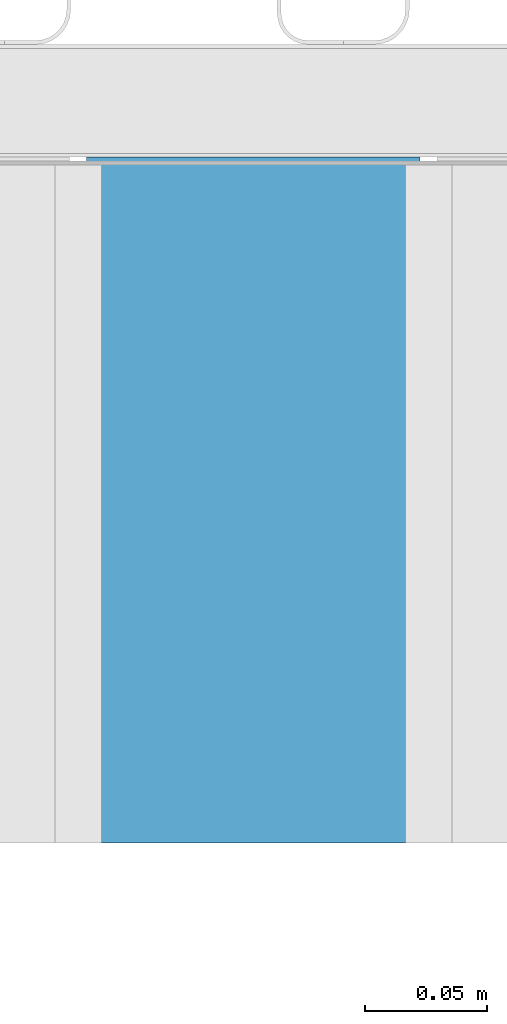
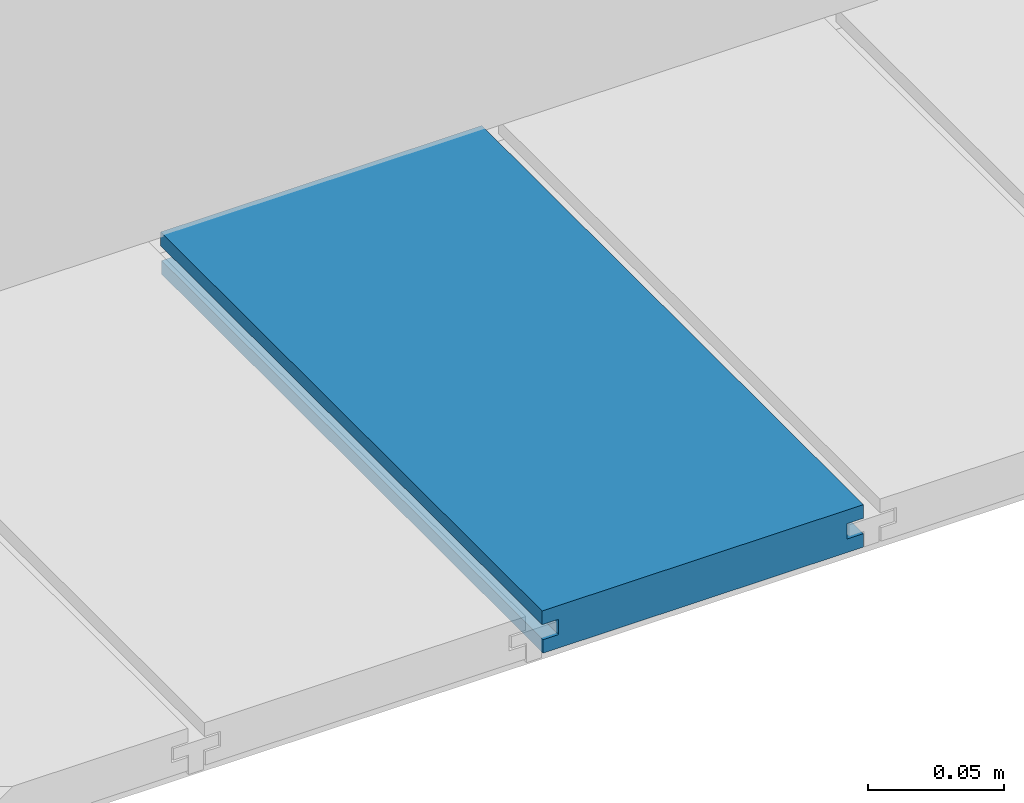
# One storey, part 15 of 33: 1 wall.
"""IFC4 building model written with IfcOpenShell, lengths in feet."""

from ifc_helpers import new_model, entity, si_unit, converted_unit, derived_unit, direction, frame, origin, place, context, subcontext, project, spatial, material, type_object, element, save


model = new_model("IFC4")

# Units and contexts
model_context = context("Model", 3, precision=0.0001, world=origin(), true_north=direction((6.12303176911189e-17, 1.0)))
body_context = subcontext(model_context, "Body", "Model", "MODEL_VIEW")
ifc_project = project(units=[converted_unit("LENGTHUNIT", "FOOT", entity("IfcRatioMeasure", 0.3048), si_unit("LENGTHUNIT", "METRE"), dimensions=[1, 0, 0, 0, 0, 0, 0]), converted_unit("AREAUNIT", "SQUARE FOOT", entity("IfcRatioMeasure", 0.09290304), si_unit("AREAUNIT", "SQUARE_METRE"), dimensions=[2, 0, 0, 0, 0, 0, 0]), converted_unit("VOLUMEUNIT", "CUBIC FOOT", entity("IfcRatioMeasure", 0.028316846592), si_unit("VOLUMEUNIT", "CUBIC_METRE"), dimensions=[3, 0, 0, 0, 0, 0, 0]), converted_unit("PLANEANGLEUNIT", "DEGREE", entity("IfcRatioMeasure", 0.0174532925199433), si_unit("PLANEANGLEUNIT", "RADIAN"), dimensions=[0, 0, 0, 0, 0, 0, 0]), si_unit("MASSUNIT", "GRAM", prefix="KILO"), derived_unit("MASSDENSITYUNIT", [(si_unit("MASSUNIT", "GRAM", prefix="KILO"), 1), (si_unit("LENGTHUNIT", "METRE"), -3)]), derived_unit("MOMENTOFINERTIAUNIT", [(si_unit("LENGTHUNIT", "METRE"), 4)]), si_unit("TIMEUNIT", "SECOND"), si_unit("FREQUENCYUNIT", "HERTZ"), si_unit("THERMODYNAMICTEMPERATUREUNIT", "DEGREE_CELSIUS"), derived_unit("THERMALTRANSMITTANCEUNIT", [(si_unit("MASSUNIT", "GRAM", prefix="KILO"), 1), (si_unit("THERMODYNAMICTEMPERATUREUNIT", "KELVIN"), -1), (si_unit("TIMEUNIT", "SECOND"), -3)]), derived_unit("VOLUMETRICFLOWRATEUNIT", [(si_unit("LENGTHUNIT", "METRE"), 3), (si_unit("TIMEUNIT", "SECOND"), -1)]), si_unit("ELECTRICCURRENTUNIT", "AMPERE"), si_unit("ELECTRICVOLTAGEUNIT", "VOLT"), si_unit("POWERUNIT", "WATT"), si_unit("FORCEUNIT", "NEWTON"), si_unit("ILLUMINANCEUNIT", "LUX"), si_unit("LUMINOUSFLUXUNIT", "LUMEN"), si_unit("LUMINOUSINTENSITYUNIT", "CANDELA"), derived_unit("USERDEFINED", [(si_unit("MASSUNIT", "GRAM", prefix="KILO"), -1), (si_unit("LENGTHUNIT", "METRE"), -2), (si_unit("TIMEUNIT", "SECOND"), 3), (si_unit("LUMINOUSFLUXUNIT", "LUMEN"), 1)]), derived_unit("LINEARVELOCITYUNIT", [(si_unit("LENGTHUNIT", "METRE"), 1), (si_unit("TIMEUNIT", "SECOND"), -1)]), si_unit("PRESSUREUNIT", "PASCAL"), derived_unit("USERDEFINED", [(si_unit("LENGTHUNIT", "METRE"), -2), (si_unit("MASSUNIT", "GRAM", prefix="KILO"), 1), (si_unit("TIMEUNIT", "SECOND"), -2)]), derived_unit("LINEARFORCEUNIT", [(si_unit("MASSUNIT", "GRAM", prefix="KILO"), 1), (si_unit("LENGTHUNIT", "METRE"), 1), (si_unit("TIMEUNIT", "SECOND"), -2), (si_unit("LENGTHUNIT", "METRE"), -1)]), derived_unit("PLANARFORCEUNIT", [(si_unit("MASSUNIT", "GRAM", prefix="KILO"), 1), (si_unit("LENGTHUNIT", "METRE"), 1), (si_unit("TIMEUNIT", "SECOND"), -2), (si_unit("LENGTHUNIT", "METRE"), -2)])], contexts=[model_context])

# Site, building, storey
site_placement = place(None, origin())
site = spatial("IfcSite", under=ifc_project, at=site_placement, CompositionType="ELEMENT")
building_placement = place(site_placement, origin())
building = spatial("IfcBuilding", under=site, at=building_placement, CompositionType="ELEMENT")
storey_placement = place(building_placement, frame((0.0, 0.0, 10.0)))
storey = spatial("IfcBuildingStorey", under=building, at=storey_placement, Name="2ND FLOOR", CompositionType="ELEMENT", Elevation=10.0000000000002)

# Wall
ifc_material = material(Name="COMPOSITE DECKING W/ HIDDEN FASTENERS", Category="Materials")
wall_type = type_object("IfcWallType", Name="Generic Models 734:Generic Models 1", PredefinedType="NOTDEFINED", material=ifc_material)
wall_placement = place(storey_placement, frame((1488.24305872981, 3.04611392999271, 0.682902157150147), z_axis=(0.0, 0.0, 1.0), x_axis=(0.0, 1.0, 0.0)))
cartesian_point_1 = entity("IfcCartesianPoint", [0.919003339851617, -0.446740923891412, 0.0])
vertex_point_1 = entity("IfcVertexPoint", cartesian_point_1)
cartesian_point_2 = entity("IfcCartesianPoint", [0.919003339851619, -0.00132475379450625, 0.0])
vertex_point_2 = entity("IfcVertexPoint", cartesian_point_2)
ifc_direction_1 = entity("IfcDirection", [0.0, 1.0, 0.0])
edge_curve_1 = entity("IfcEdgeCurve", vertex_point_1, vertex_point_2, entity("IfcTrimmedCurve", entity("IfcLine", cartesian_point_1, entity("IfcVector", ifc_direction_1, 1.0)), [cartesian_point_1], [cartesian_point_2], True, "CARTESIAN"), True)
cartesian_point_3 = entity("IfcCartesianPoint", [0.919003339851619, -0.00132475379450625, 0.0198779960861479])
vertex_point_3 = entity("IfcVertexPoint", cartesian_point_3)
ifc_direction_2 = entity("IfcDirection", [0.0, 0.0, 1.0])
edge_curve_2 = entity("IfcEdgeCurve", vertex_point_2, vertex_point_3, entity("IfcTrimmedCurve", entity("IfcLine", cartesian_point_2, entity("IfcVector", ifc_direction_2, 1.0)), [cartesian_point_2], [cartesian_point_3], True, "CARTESIAN"), True)
cartesian_point_4 = entity("IfcCartesianPoint", [0.919003339851619, -0.0228400010807945, 0.0198779960861479])
vertex_point_4 = entity("IfcVertexPoint", cartesian_point_4)
ifc_direction_3 = entity("IfcDirection", [0.0, -1.0, 0.0])
edge_curve_3 = entity("IfcEdgeCurve", vertex_point_3, vertex_point_4, entity("IfcTrimmedCurve", entity("IfcLine", cartesian_point_3, entity("IfcVector", ifc_direction_3, 1.0)), [cartesian_point_3], [cartesian_point_4], True, "CARTESIAN"), True)
cartesian_point_5 = entity("IfcCartesianPoint", [0.919003339851619, -0.0228400010807945, 0.0422987663426522])
vertex_point_5 = entity("IfcVertexPoint", cartesian_point_5)
edge_curve_4 = entity("IfcEdgeCurve", vertex_point_4, vertex_point_5, entity("IfcTrimmedCurve", entity("IfcLine", cartesian_point_4, entity("IfcVector", ifc_direction_2, 1.0)), [cartesian_point_4], [cartesian_point_5], True, "CARTESIAN"), True)
cartesian_point_6 = entity("IfcCartesianPoint", [0.919003339851619, 0.0, 0.0422987663426522])
vertex_point_6 = entity("IfcVertexPoint", cartesian_point_6)
edge_curve_5 = entity("IfcEdgeCurve", vertex_point_5, vertex_point_6, entity("IfcTrimmedCurve", entity("IfcLine", cartesian_point_5, entity("IfcVector", ifc_direction_1, 1.0)), [cartesian_point_5], [cartesian_point_6], True, "CARTESIAN"), True)
cartesian_point_7 = entity("IfcCartesianPoint", [0.919003339851619, 0.0, 0.0625000000000551])
vertex_point_7 = entity("IfcVertexPoint", cartesian_point_7)
edge_curve_6 = entity("IfcEdgeCurve", vertex_point_6, vertex_point_7, entity("IfcTrimmedCurve", entity("IfcLine", cartesian_point_6, entity("IfcVector", ifc_direction_2, 1.0)), [cartesian_point_6], [cartesian_point_7], True, "CARTESIAN"), True)
cartesian_point_8 = entity("IfcCartesianPoint", [0.919003339851617, -0.446740923891639, 0.0625])
vertex_point_8 = entity("IfcVertexPoint", cartesian_point_8)
edge_curve_7 = entity("IfcEdgeCurve", vertex_point_7, vertex_point_8, entity("IfcTrimmedCurve", entity("IfcLine", cartesian_point_7, entity("IfcVector", ifc_direction_3, 1.0)), [cartesian_point_7], [cartesian_point_8], True, "CARTESIAN"), True)
cartesian_point_9 = entity("IfcCartesianPoint", [0.919003339851617, -0.446740923891639, 0.0422987663426522])
vertex_point_9 = entity("IfcVertexPoint", cartesian_point_9)
ifc_direction_4 = entity("IfcDirection", [0.0, 0.0, -1.0])
edge_curve_8 = entity("IfcEdgeCurve", vertex_point_8, vertex_point_9, entity("IfcTrimmedCurve", entity("IfcLine", cartesian_point_8, entity("IfcVector", ifc_direction_4, 1.0)), [cartesian_point_8], [cartesian_point_9], True, "CARTESIAN"), True)
cartesian_point_10 = entity("IfcCartesianPoint", [0.919003339851617, -0.423900922810617, 0.0422987663426522])
vertex_point_10 = entity("IfcVertexPoint", cartesian_point_10)
edge_curve_9 = entity("IfcEdgeCurve", vertex_point_9, vertex_point_10, entity("IfcTrimmedCurve", entity("IfcLine", cartesian_point_9, entity("IfcVector", ifc_direction_1, 1.0)), [cartesian_point_9], [cartesian_point_10], True, "CARTESIAN"), True)
cartesian_point_11 = entity("IfcCartesianPoint", [0.919003339851617, -0.423900922810617, 0.0198779960861479])
vertex_point_11 = entity("IfcVertexPoint", cartesian_point_11)
edge_curve_10 = entity("IfcEdgeCurve", vertex_point_10, vertex_point_11, entity("IfcTrimmedCurve", entity("IfcLine", cartesian_point_10, entity("IfcVector", ifc_direction_4, 1.0)), [cartesian_point_10], [cartesian_point_11], True, "CARTESIAN"), True)
cartesian_point_12 = entity("IfcCartesianPoint", [0.919003339851617, -0.446740923891412, 0.0198779960861479])
vertex_point_12 = entity("IfcVertexPoint", cartesian_point_12)
edge_curve_11 = entity("IfcEdgeCurve", vertex_point_11, vertex_point_12, entity("IfcTrimmedCurve", entity("IfcLine", cartesian_point_11, entity("IfcVector", ifc_direction_3, 1.0)), [cartesian_point_11], [cartesian_point_12], True, "CARTESIAN"), True)
edge_curve_12 = entity("IfcEdgeCurve", vertex_point_12, vertex_point_1, entity("IfcTrimmedCurve", entity("IfcLine", cartesian_point_12, entity("IfcVector", ifc_direction_4, 1.0)), [cartesian_point_12], [cartesian_point_1], True, "CARTESIAN"), True)
ifc_direction_5 = entity("IfcDirection", [1.0, 0.0, 0.0])
cartesian_point_13 = entity("IfcCartesianPoint", [0.0, -0.446740923891412, 0.0])
vertex_point_13 = entity("IfcVertexPoint", cartesian_point_13)
cartesian_point_14 = entity("IfcCartesianPoint", [0.0, -0.446740923891412, 0.0198779960861479])
vertex_point_14 = entity("IfcVertexPoint", cartesian_point_14)
edge_curve_13 = entity("IfcEdgeCurve", vertex_point_13, vertex_point_14, entity("IfcTrimmedCurve", entity("IfcLine", cartesian_point_13, entity("IfcVector", ifc_direction_2, 1.0)), [cartesian_point_13], [cartesian_point_14], True, "CARTESIAN"), True)
cartesian_point_15 = entity("IfcCartesianPoint", [0.0, -0.423900922810617, 0.0198779960861479])
vertex_point_15 = entity("IfcVertexPoint", cartesian_point_15)
edge_curve_14 = entity("IfcEdgeCurve", vertex_point_14, vertex_point_15, entity("IfcTrimmedCurve", entity("IfcLine", cartesian_point_14, entity("IfcVector", ifc_direction_1, 1.0)), [cartesian_point_14], [cartesian_point_15], True, "CARTESIAN"), True)
cartesian_point_16 = entity("IfcCartesianPoint", [0.0, -0.423900922810617, 0.0422987663426522])
vertex_point_16 = entity("IfcVertexPoint", cartesian_point_16)
edge_curve_15 = entity("IfcEdgeCurve", vertex_point_15, vertex_point_16, entity("IfcTrimmedCurve", entity("IfcLine", cartesian_point_15, entity("IfcVector", ifc_direction_2, 1.0)), [cartesian_point_15], [cartesian_point_16], True, "CARTESIAN"), True)
cartesian_point_17 = entity("IfcCartesianPoint", [0.0, -0.446740923891639, 0.0422987663426522])
vertex_point_17 = entity("IfcVertexPoint", cartesian_point_17)
edge_curve_16 = entity("IfcEdgeCurve", vertex_point_16, vertex_point_17, entity("IfcTrimmedCurve", entity("IfcLine", cartesian_point_16, entity("IfcVector", ifc_direction_3, 1.0)), [cartesian_point_16], [cartesian_point_17], True, "CARTESIAN"), True)
cartesian_point_18 = entity("IfcCartesianPoint", [0.0, -0.446740923891639, 0.0625])
vertex_point_18 = entity("IfcVertexPoint", cartesian_point_18)
edge_curve_17 = entity("IfcEdgeCurve", vertex_point_17, vertex_point_18, entity("IfcTrimmedCurve", entity("IfcLine", cartesian_point_17, entity("IfcVector", ifc_direction_2, 1.0)), [cartesian_point_17], [cartesian_point_18], True, "CARTESIAN"), True)
cartesian_point_19 = entity("IfcCartesianPoint", [0.0, 0.0, 0.0625000000000551])
vertex_point_19 = entity("IfcVertexPoint", cartesian_point_19)
edge_curve_18 = entity("IfcEdgeCurve", vertex_point_18, vertex_point_19, entity("IfcTrimmedCurve", entity("IfcLine", cartesian_point_18, entity("IfcVector", ifc_direction_1, 1.0)), [cartesian_point_18], [cartesian_point_19], True, "CARTESIAN"), True)
cartesian_point_20 = entity("IfcCartesianPoint", [0.0, 0.0, 0.0422987663426522])
vertex_point_20 = entity("IfcVertexPoint", cartesian_point_20)
edge_curve_19 = entity("IfcEdgeCurve", vertex_point_19, vertex_point_20, entity("IfcTrimmedCurve", entity("IfcLine", cartesian_point_19, entity("IfcVector", ifc_direction_4, 1.0)), [cartesian_point_19], [cartesian_point_20], True, "CARTESIAN"), True)
cartesian_point_21 = entity("IfcCartesianPoint", [0.0, -0.0228400010807945, 0.0422987663426522])
vertex_point_21 = entity("IfcVertexPoint", cartesian_point_21)
edge_curve_20 = entity("IfcEdgeCurve", vertex_point_20, vertex_point_21, entity("IfcTrimmedCurve", entity("IfcLine", cartesian_point_20, entity("IfcVector", ifc_direction_3, 1.0)), [cartesian_point_20], [cartesian_point_21], True, "CARTESIAN"), True)
cartesian_point_22 = entity("IfcCartesianPoint", [0.0, -0.0228400010807945, 0.0198779960861479])
vertex_point_22 = entity("IfcVertexPoint", cartesian_point_22)
edge_curve_21 = entity("IfcEdgeCurve", vertex_point_21, vertex_point_22, entity("IfcTrimmedCurve", entity("IfcLine", cartesian_point_21, entity("IfcVector", ifc_direction_4, 1.0)), [cartesian_point_21], [cartesian_point_22], True, "CARTESIAN"), True)
cartesian_point_23 = entity("IfcCartesianPoint", [0.0, -0.00132475379450625, 0.0198779960861479])
vertex_point_23 = entity("IfcVertexPoint", cartesian_point_23)
edge_curve_22 = entity("IfcEdgeCurve", vertex_point_22, vertex_point_23, entity("IfcTrimmedCurve", entity("IfcLine", cartesian_point_22, entity("IfcVector", ifc_direction_1, 1.0)), [cartesian_point_22], [cartesian_point_23], True, "CARTESIAN"), True)
cartesian_point_24 = entity("IfcCartesianPoint", [0.0, -0.00132475379450625, 0.0])
vertex_point_24 = entity("IfcVertexPoint", cartesian_point_24)
edge_curve_23 = entity("IfcEdgeCurve", vertex_point_23, vertex_point_24, entity("IfcTrimmedCurve", entity("IfcLine", cartesian_point_23, entity("IfcVector", ifc_direction_4, 1.0)), [cartesian_point_23], [cartesian_point_24], True, "CARTESIAN"), True)
edge_curve_24 = entity("IfcEdgeCurve", vertex_point_24, vertex_point_13, entity("IfcTrimmedCurve", entity("IfcLine", cartesian_point_24, entity("IfcVector", ifc_direction_3, 1.0)), [cartesian_point_24], [cartesian_point_13], True, "CARTESIAN"), True)
ifc_direction_6 = entity("IfcDirection", [-1.0, 0.0, 0.0])
edge_curve_25 = entity("IfcEdgeCurve", vertex_point_13, vertex_point_1, entity("IfcTrimmedCurve", entity("IfcLine", cartesian_point_13, entity("IfcVector", ifc_direction_5, 1.0)), [cartesian_point_13], [cartesian_point_1], True, "CARTESIAN"), True)
edge_curve_26 = entity("IfcEdgeCurve", vertex_point_12, vertex_point_14, entity("IfcTrimmedCurve", entity("IfcLine", cartesian_point_14, entity("IfcVector", ifc_direction_6, 1.0)), [cartesian_point_12], [cartesian_point_14], True, "CARTESIAN"), True)
edge_curve_27 = entity("IfcEdgeCurve", vertex_point_18, vertex_point_8, entity("IfcTrimmedCurve", entity("IfcLine", cartesian_point_18, entity("IfcVector", ifc_direction_5, 1.0)), [cartesian_point_18], [cartesian_point_8], True, "CARTESIAN"), True)
edge_curve_28 = entity("IfcEdgeCurve", vertex_point_7, vertex_point_19, entity("IfcTrimmedCurve", entity("IfcLine", cartesian_point_19, entity("IfcVector", ifc_direction_6, 1.0)), [cartesian_point_7], [cartesian_point_19], True, "CARTESIAN"), True)
edge_curve_29 = entity("IfcEdgeCurve", vertex_point_6, vertex_point_20, entity("IfcTrimmedCurve", entity("IfcLine", cartesian_point_20, entity("IfcVector", ifc_direction_6, 1.0)), [cartesian_point_6], [cartesian_point_20], True, "CARTESIAN"), True)
edge_curve_30 = entity("IfcEdgeCurve", vertex_point_24, vertex_point_2, entity("IfcTrimmedCurve", entity("IfcLine", cartesian_point_24, entity("IfcVector", ifc_direction_5, 1.0)), [cartesian_point_24], [cartesian_point_2], True, "CARTESIAN"), True)
edge_curve_31 = entity("IfcEdgeCurve", vertex_point_17, vertex_point_9, entity("IfcTrimmedCurve", entity("IfcLine", cartesian_point_17, entity("IfcVector", ifc_direction_5, 1.0)), [cartesian_point_17], [cartesian_point_9], True, "CARTESIAN"), True)
edge_curve_32 = entity("IfcEdgeCurve", vertex_point_5, vertex_point_21, entity("IfcTrimmedCurve", entity("IfcLine", cartesian_point_21, entity("IfcVector", ifc_direction_6, 1.0)), [cartesian_point_5], [cartesian_point_21], True, "CARTESIAN"), True)
edge_curve_33 = entity("IfcEdgeCurve", vertex_point_4, vertex_point_22, entity("IfcTrimmedCurve", entity("IfcLine", cartesian_point_22, entity("IfcVector", ifc_direction_6, 1.0)), [cartesian_point_4], [cartesian_point_22], True, "CARTESIAN"), True)
edge_curve_34 = entity("IfcEdgeCurve", vertex_point_3, vertex_point_23, entity("IfcTrimmedCurve", entity("IfcLine", cartesian_point_23, entity("IfcVector", ifc_direction_6, 1.0)), [cartesian_point_3], [cartesian_point_23], True, "CARTESIAN"), True)
edge_curve_35 = entity("IfcEdgeCurve", vertex_point_11, vertex_point_15, entity("IfcTrimmedCurve", entity("IfcLine", cartesian_point_15, entity("IfcVector", ifc_direction_6, 1.0)), [cartesian_point_11], [cartesian_point_15], True, "CARTESIAN"), True)
edge_curve_36 = entity("IfcEdgeCurve", vertex_point_10, vertex_point_16, entity("IfcTrimmedCurve", entity("IfcLine", cartesian_point_16, entity("IfcVector", ifc_direction_6, 1.0)), [cartesian_point_10], [cartesian_point_16], True, "CARTESIAN"), True)
element("IfcWall", 1, at=wall_placement, inside=storey, type_object=wall_type, material=ifc_material, Name="Generic Models 734:Generic Models 1", ObjectType="Generic Models 734:Generic Models 1", PredefinedType="NOTDEFINED", context=body_context, shape_type="AdvancedBrep", body=[
    entity("IfcAdvancedBrep", entity("IfcClosedShell", [entity("IfcAdvancedFace", [entity("IfcFaceOuterBound", entity("IfcEdgeLoop", [entity("IfcOrientedEdge", None, None, edge_curve_1, True), entity("IfcOrientedEdge", None, None, edge_curve_2, True), entity("IfcOrientedEdge", None, None, edge_curve_3, True), entity("IfcOrientedEdge", None, None, edge_curve_4, True), entity("IfcOrientedEdge", None, None, edge_curve_5, True), entity("IfcOrientedEdge", None, None, edge_curve_6, True), entity("IfcOrientedEdge", None, None, edge_curve_7, True), entity("IfcOrientedEdge", None, None, edge_curve_8, True), entity("IfcOrientedEdge", None, None, edge_curve_9, True), entity("IfcOrientedEdge", None, None, edge_curve_10, True), entity("IfcOrientedEdge", None, None, edge_curve_11, True), entity("IfcOrientedEdge", None, None, edge_curve_12, True)]), True)], entity("IfcPlane", entity("IfcAxis2Placement3D", entity("IfcCartesianPoint", [0.919003339851617, -0.446740923891412, -0.0208333333328241]), ifc_direction_5, ifc_direction_4)), True), entity("IfcAdvancedFace", [entity("IfcFaceOuterBound", entity("IfcEdgeLoop", [entity("IfcOrientedEdge", None, None, edge_curve_13, True), entity("IfcOrientedEdge", None, None, edge_curve_14, True), entity("IfcOrientedEdge", None, None, edge_curve_15, True), entity("IfcOrientedEdge", None, None, edge_curve_16, True), entity("IfcOrientedEdge", None, None, edge_curve_17, True), entity("IfcOrientedEdge", None, None, edge_curve_18, True), entity("IfcOrientedEdge", None, None, edge_curve_19, True), entity("IfcOrientedEdge", None, None, edge_curve_20, True), entity("IfcOrientedEdge", None, None, edge_curve_21, True), entity("IfcOrientedEdge", None, None, edge_curve_22, True), entity("IfcOrientedEdge", None, None, edge_curve_23, True), entity("IfcOrientedEdge", None, None, edge_curve_24, True)]), True)], entity("IfcPlane", entity("IfcAxis2Placement3D", entity("IfcCartesianPoint", [0.0, -0.446740923891412, -0.0208333333328241]), ifc_direction_6, ifc_direction_2)), True), entity("IfcAdvancedFace", [entity("IfcFaceOuterBound", entity("IfcEdgeLoop", [entity("IfcOrientedEdge", None, None, edge_curve_13, False), entity("IfcOrientedEdge", None, None, edge_curve_25, True), entity("IfcOrientedEdge", None, None, edge_curve_12, False), entity("IfcOrientedEdge", None, None, edge_curve_26, True)]), True)], entity("IfcPlane", entity("IfcAxis2Placement3D", cartesian_point_13, ifc_direction_3, ifc_direction_5)), True), entity("IfcAdvancedFace", [entity("IfcFaceOuterBound", entity("IfcEdgeLoop", [entity("IfcOrientedEdge", None, None, edge_curve_18, False), entity("IfcOrientedEdge", None, None, edge_curve_27, True), entity("IfcOrientedEdge", None, None, edge_curve_7, False), entity("IfcOrientedEdge", None, None, edge_curve_28, True)]), True)], entity("IfcPlane", entity("IfcAxis2Placement3D", cartesian_point_18, ifc_direction_2, ifc_direction_5)), True), entity("IfcAdvancedFace", [entity("IfcFaceOuterBound", entity("IfcEdgeLoop", [entity("IfcOrientedEdge", None, None, edge_curve_19, False), entity("IfcOrientedEdge", None, None, edge_curve_28, False), entity("IfcOrientedEdge", None, None, edge_curve_6, False), entity("IfcOrientedEdge", None, None, edge_curve_29, True)]), True)], entity("IfcPlane", entity("IfcAxis2Placement3D", cartesian_point_19, ifc_direction_1, ifc_direction_5)), True), entity("IfcAdvancedFace", [entity("IfcFaceOuterBound", entity("IfcEdgeLoop", [entity("IfcOrientedEdge", None, None, edge_curve_24, False), entity("IfcOrientedEdge", None, None, edge_curve_30, True), entity("IfcOrientedEdge", None, None, edge_curve_1, False), entity("IfcOrientedEdge", None, None, edge_curve_25, False)]), True)], entity("IfcPlane", entity("IfcAxis2Placement3D", cartesian_point_24, ifc_direction_4, ifc_direction_5)), True), entity("IfcAdvancedFace", [entity("IfcFaceOuterBound", entity("IfcEdgeLoop", [entity("IfcOrientedEdge", None, None, edge_curve_17, False), entity("IfcOrientedEdge", None, None, edge_curve_31, True), entity("IfcOrientedEdge", None, None, edge_curve_8, False), entity("IfcOrientedEdge", None, None, edge_curve_27, False)]), True)], entity("IfcPlane", entity("IfcAxis2Placement3D", cartesian_point_17, ifc_direction_3, ifc_direction_5)), True), entity("IfcAdvancedFace", [entity("IfcFaceOuterBound", entity("IfcEdgeLoop", [entity("IfcOrientedEdge", None, None, edge_curve_20, False), entity("IfcOrientedEdge", None, None, edge_curve_29, False), entity("IfcOrientedEdge", None, None, edge_curve_5, False), entity("IfcOrientedEdge", None, None, edge_curve_32, True)]), True)], entity("IfcPlane", entity("IfcAxis2Placement3D", cartesian_point_20, ifc_direction_4, ifc_direction_5)), True), entity("IfcAdvancedFace", [entity("IfcFaceOuterBound", entity("IfcEdgeLoop", [entity("IfcOrientedEdge", None, None, edge_curve_21, False), entity("IfcOrientedEdge", None, None, edge_curve_32, False), entity("IfcOrientedEdge", None, None, edge_curve_4, False), entity("IfcOrientedEdge", None, None, edge_curve_33, True)]), True)], entity("IfcPlane", entity("IfcAxis2Placement3D", cartesian_point_21, ifc_direction_1, ifc_direction_5)), True), entity("IfcAdvancedFace", [entity("IfcFaceOuterBound", entity("IfcEdgeLoop", [entity("IfcOrientedEdge", None, None, edge_curve_22, False), entity("IfcOrientedEdge", None, None, edge_curve_33, False), entity("IfcOrientedEdge", None, None, edge_curve_3, False), entity("IfcOrientedEdge", None, None, edge_curve_34, True)]), True)], entity("IfcPlane", entity("IfcAxis2Placement3D", cartesian_point_22, ifc_direction_2, ifc_direction_5)), True), entity("IfcAdvancedFace", [entity("IfcFaceOuterBound", entity("IfcEdgeLoop", [entity("IfcOrientedEdge", None, None, edge_curve_23, False), entity("IfcOrientedEdge", None, None, edge_curve_34, False), entity("IfcOrientedEdge", None, None, edge_curve_2, False), entity("IfcOrientedEdge", None, None, edge_curve_30, False)]), True)], entity("IfcPlane", entity("IfcAxis2Placement3D", cartesian_point_23, ifc_direction_1, ifc_direction_5)), True), entity("IfcAdvancedFace", [entity("IfcFaceOuterBound", entity("IfcEdgeLoop", [entity("IfcOrientedEdge", None, None, edge_curve_14, False), entity("IfcOrientedEdge", None, None, edge_curve_26, False), entity("IfcOrientedEdge", None, None, edge_curve_11, False), entity("IfcOrientedEdge", None, None, edge_curve_35, True)]), True)], entity("IfcPlane", entity("IfcAxis2Placement3D", cartesian_point_14, ifc_direction_2, ifc_direction_5)), True), entity("IfcAdvancedFace", [entity("IfcFaceOuterBound", entity("IfcEdgeLoop", [entity("IfcOrientedEdge", None, None, edge_curve_15, False), entity("IfcOrientedEdge", None, None, edge_curve_35, False), entity("IfcOrientedEdge", None, None, edge_curve_10, False), entity("IfcOrientedEdge", None, None, edge_curve_36, True)]), True)], entity("IfcPlane", entity("IfcAxis2Placement3D", cartesian_point_15, ifc_direction_3, ifc_direction_5)), True), entity("IfcAdvancedFace", [entity("IfcFaceOuterBound", entity("IfcEdgeLoop", [entity("IfcOrientedEdge", None, None, edge_curve_16, False), entity("IfcOrientedEdge", None, None, edge_curve_36, False), entity("IfcOrientedEdge", None, None, edge_curve_9, False), entity("IfcOrientedEdge", None, None, edge_curve_31, False)]), True)], entity("IfcPlane", entity("IfcAxis2Placement3D", cartesian_point_16, ifc_direction_4, ifc_direction_5)), True)])),
])

save(model, "model.ifc")
